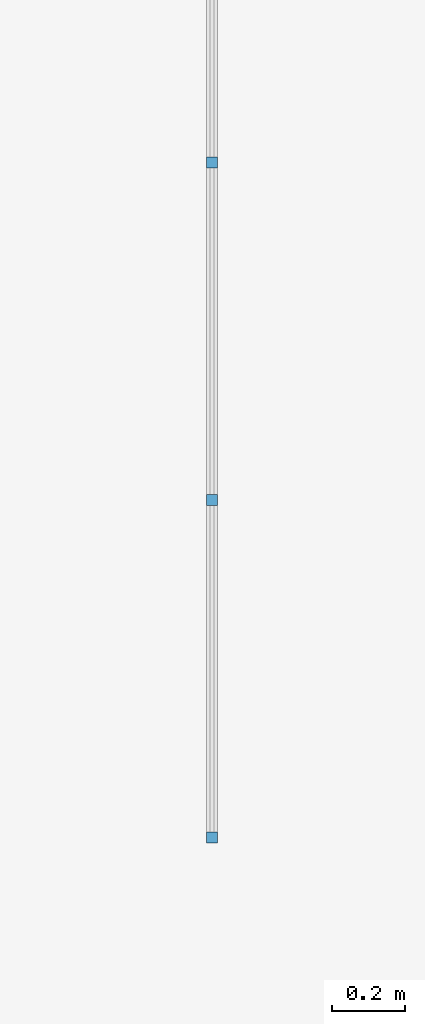
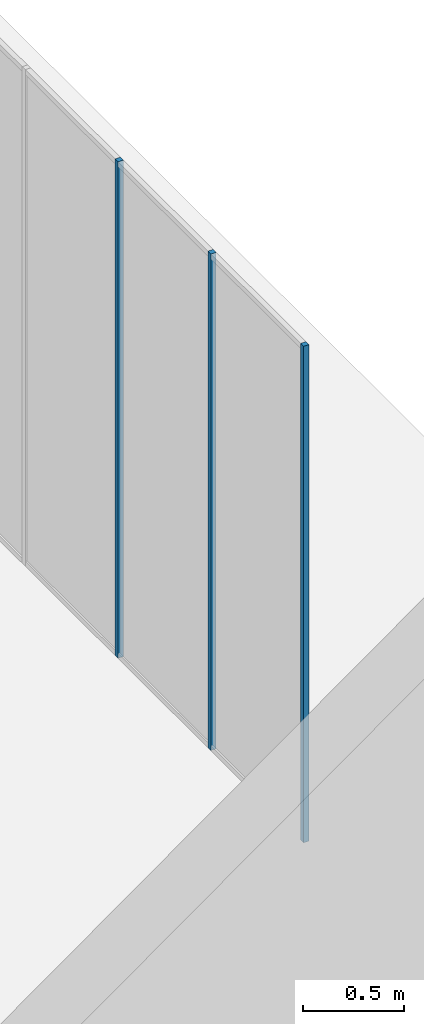
# One storey, part 4 of 8: 3 members, 1 element without a shape of its own.
"""IFC2X3 building model written with IfcOpenShell, lengths in millimetres."""

from ifc_helpers import new_model, entity, si_unit, converted_unit, direction, frame, frame_2d, origin, place, context, subcontext, project, spatial, rectangle, extrude, element, aggregate, save


model = new_model("IFC2X3")

# Units and contexts
model_context = context("Model", 3, precision=1e-06, world=origin(), true_north=direction((2.0, 6.12303176911189e-17, 1.0)))
context_of_model = context(None, 3, precision=1e-06, world=origin(), true_north=direction((2.0, 6.12303176911189e-17, 1.0)))
body_context = subcontext(model_context, "Body", "Model", "MODEL_VIEW")
ifc_project = project(units=[si_unit("LENGTHUNIT", "METRE", prefix="MILLI"), si_unit("AREAUNIT", "SQUARE_METRE", prefix="MILLI"), si_unit("VOLUMEUNIT", "CUBIC_METRE", prefix="MILLI"), converted_unit("PLANEANGLEUNIT", "DEGREE", entity("IfcRatioMeasure", 0.0174532925199433), si_unit("PLANEANGLEUNIT", "RADIAN"), dimensions=[0, 0, 0, 0, 0, 0, 0]), si_unit("TIMEUNIT", "SECOND")], contexts=[model_context, context_of_model])

# Site, building, storey
site_placement = place(None, origin())
site = spatial("IfcSite", under=ifc_project, at=site_placement, CompositionType="ELEMENT")
building_placement = place(site_placement, origin())
building = spatial("IfcBuilding", under=site, at=building_placement, CompositionType="ELEMENT")
storey_placement = place(building_placement, frame((0.0, 0.0, 1500.0)))
storey = spatial("IfcBuildingStorey", under=building, at=storey_placement, Name="Level 1", CompositionType="ELEMENT", Elevation=1500.0)

# Curtain wall, members
curtain_wall_placement = place(storey_placement, origin())
curtain_wall = element("IfcCurtainWall", 1, at=curtain_wall_placement, inside=storey, Name="Curtain Wall:Curtain Wall", ObjectType="Curtain Wall:Curtain Wall:334")
member_1_placement = place(storey_placement, origin())
member_1 = element("IfcMember", 2, at=member_1_placement, Name="Curtain Wall:Curtain Wall:8490", ObjectType="Curtain Wall:Curtain Wall:8490", context=body_context, shape_type="SweptSolid", body=[
    extrude(rectangle(XDim=29.9999999999997, YDim=29.9999999999997, at=frame_2d((-1.08268949361445e-12, 0.0), x_axis=(1.0, 0.0))), frame((18734.4440927411, -3406.25, 0.0)), (0.0, 0.0, 1.0), 3000.0),
])
member_2_placement = place(storey_placement, origin())
member_2 = element("IfcMember", 3, at=member_2_placement, Name="Curtain Wall:Curtain Wall:8490", ObjectType="Curtain Wall:Curtain Wall:8490", context=body_context, shape_type="SweptSolid", body=[
    extrude(rectangle(XDim=29.9999999999997, YDim=29.9999999999997, at=frame_2d((-1.08268949361445e-12, 0.0), x_axis=(1.0, 0.0))), frame((18734.4440927411, -2487.5, 0.0)), (0.0, 0.0, 1.0), 3000.0),
])
member_3_placement = place(storey_placement, origin())
member_3 = element("IfcMember", 4, at=member_3_placement, Name="Curtain Wall:Curtain Wall:8490", ObjectType="Curtain Wall:Curtain Wall:8490", context=body_context, shape_type="SweptSolid", body=[
    extrude(rectangle(XDim=29.9999999999997, YDim=29.9999999999997, at=frame_2d((-1.08268949361445e-12, 0.0), x_axis=(1.0, 0.0))), frame((18734.4440927411, -4325.0, 0.0)), (0.0, 0.0, 1.0), 3000.0),
])
aggregate(curtain_wall, [member_1, member_2, member_3])

save(model, "model.ifc")
